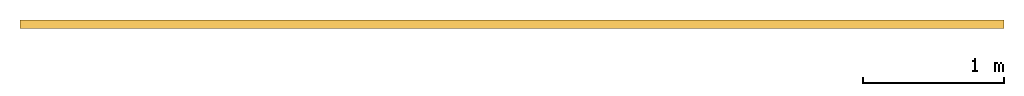
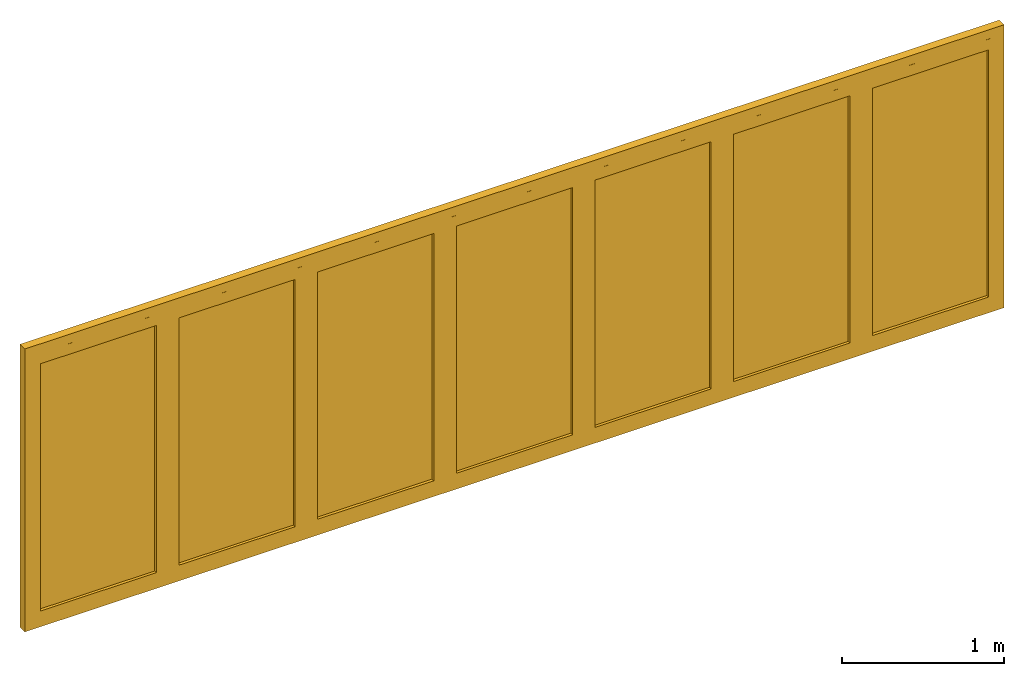
# One storey: 1 door.
"""IFC2X3 building model written with IfcOpenShell, lengths in millimetres."""

from ifc_helpers import new_model, entity, si_unit, converted_unit, direction, frame, frame_2d, origin, origin_2d_with_axis, place, context, subcontext, project, spatial, polyline, rectangle, outline, extrude, source, transform, mapped, material, material_list, type_object, type_shapes, element, save


model = new_model("IFC2X3")

# Units and contexts
model_context = context("Model", 3, precision=1e-06, world=origin(), true_north=direction((2.0, -1.71512652170913e-15, 1.0)))
context_of_model = context(None, 3, precision=1e-06, world=origin(), true_north=direction((2.0, -1.71512652170913e-15, 1.0)))
body_context = subcontext(model_context, "Body", "Model", "MODEL_VIEW")
ifc_project = project(units=[si_unit("LENGTHUNIT", "METRE", prefix="MILLI"), si_unit("AREAUNIT", "SQUARE_METRE", prefix="MILLI"), si_unit("VOLUMEUNIT", "CUBIC_METRE", prefix="MILLI"), converted_unit("PLANEANGLEUNIT", "DEGREE", entity("IfcRatioMeasure", 0.0174532925199433), si_unit("PLANEANGLEUNIT", "RADIAN"), dimensions=[0, 0, 0, 0, 0, 0, 0]), si_unit("TIMEUNIT", "SECOND")], contexts=[model_context, context_of_model])

# Site, building, storey
site_placement = place(None, origin())
site = spatial("IfcSite", under=ifc_project, at=site_placement, CompositionType="ELEMENT")
building_placement = place(site_placement, origin())
building = spatial("IfcBuilding", under=site, at=building_placement, CompositionType="ELEMENT")
storey_placement = place(building_placement, origin())
storey = spatial("IfcBuildingStorey", under=building, at=storey_placement, Name="Ground Floor", CompositionType="ELEMENT", Elevation=0.0)

# Door
ifc_material_1 = material(Name="Glass-Blue")
ifc_material_2 = material(Name="Mtl-Aluminium")
ifc_material_list = material_list([ifc_material_1, ifc_material_2])
door_style = type_object("IfcDoorStyle", ConstructionType="NOTDEFINED", OperationType="NOTDEFINED", ParameterTakesPrecedence=False, Sizeable=False)
shared_shape = source(origin(), body_context, "Body", "SweptSolid", [
    extrude(rectangle(XDim=829.9714, YDim=18.0, at=frame_2d((5.6843418860808e-13, 1.68753899743024e-14), x_axis=(1.0, 0.0))), frame((6924.4291, 270.25, 80.7), z_axis=(0.0, 0.0, 1.0), x_axis=(-1.0, 0.0, 0.0)), (0.0, 0.0, 1.0), 1868.6),
    extrude(outline(polyline([(-495.685699999999, -1015.0), (495.6857, -1015.0), (495.6857, 1015.0), (-495.685699999999, 1015.0), (-495.685699999999, -1015.0)]), holes=[polyline([(414.9857, 934.3), (414.9857, -934.3), (-414.985699999999, -934.3), (-414.985699999999, 934.3), (414.9857, 934.3)])]), frame((6924.4291, 240.5, 1015.0), z_axis=(0.0, 1.0, 0.0), x_axis=(-1.0, 0.0, 0.0)), (0.0, 0.0, 1.0), 59.5),
    extrude(rectangle(XDim=829.9715, YDim=18.0, at=frame_2d((5.40012479177676e-13, 1.68753899743024e-14), x_axis=(1.0, 0.0))), frame((5933.05765, 270.25, 80.7), z_axis=(0.0, 0.0, 1.0), x_axis=(-1.0, 0.0, 0.0)), (0.0, 0.0, 1.0), 1868.6),
    extrude(outline(polyline([(-495.68575, -1015.0), (495.685750000001, -1015.0), (495.685750000001, 1015.0), (-495.68575, 1015.0), (-495.68575, -1015.0)]), holes=[polyline([(414.985750000001, 934.3), (414.985750000001, -934.3), (-414.98575, -934.3), (-414.98575, 934.3), (414.985750000001, 934.3)])]), frame((5933.05765, 240.5, 1015.0), z_axis=(0.0, 1.0, 0.0), x_axis=(-1.0, 0.0, 0.0)), (0.0, 0.0, 1.0), 59.5),
    extrude(rectangle(XDim=829.97139, YDim=18.0, at=frame_2d((0.0, 1.68753899743024e-14), x_axis=(1.0, 0.0))), frame((4941.686205, 270.25, 80.7), z_axis=(0.0, 0.0, 1.0), x_axis=(-1.0, 0.0, 0.0)), (0.0, 0.0, 1.0), 1868.6),
    extrude(outline(polyline([(-495.685695, -1015.0), (495.685695, -1015.0), (495.685695, 1015.0), (-495.685695, 1015.0), (-495.685695, -1015.0)]), holes=[polyline([(414.985694999999, 934.3), (414.985694999999, -934.3), (-414.985695000001, -934.3), (-414.985695000001, 934.3), (414.985694999999, 934.3)])]), frame((4941.686205, 240.5, 1015.0), z_axis=(0.0, 1.0, 0.0), x_axis=(-1.0, 0.0, 0.0)), (0.0, 0.0, 1.0), 59.5),
    extrude(rectangle(XDim=829.97142, YDim=18.0, at=frame_2d((0.0, 1.68753899743024e-14), x_axis=(1.0, 0.0))), frame((3950.3148, 270.25, 80.7), z_axis=(0.0, 0.0, 1.0), x_axis=(-1.0, 0.0, 0.0)), (0.0, 0.0, 1.0), 1868.6),
    extrude(outline(polyline([(-495.685709999999, -1015.0), (495.68571, -1015.0), (495.68571, 1015.0), (-495.685709999999, 1015.0), (-495.685709999999, -1015.0)]), holes=[polyline([(414.985710000001, 934.3), (414.985710000001, -934.3), (-414.985709999999, -934.3), (-414.985709999999, 934.3), (414.985710000001, 934.3)])]), frame((3950.3148, 240.5, 1015.0), z_axis=(0.0, 1.0, 0.0), x_axis=(-1.0, 0.0, 0.0)), (0.0, 0.0, 1.0), 59.5),
    extrude(rectangle(XDim=829.97139, YDim=18.0, at=frame_2d((0.0, 1.68753899743024e-14), x_axis=(1.0, 0.0))), frame((2958.943395, 270.25, 80.7), z_axis=(0.0, 0.0, 1.0), x_axis=(-1.0, 0.0, 0.0)), (0.0, 0.0, 1.0), 1868.6),
    extrude(outline(polyline([(-495.685695, -1015.0), (495.685695000001, -1015.0), (495.685695000001, 1015.0), (-495.685695, 1015.0), (-495.685695, -1015.0)]), holes=[polyline([(414.985695000001, 934.3), (414.985695000001, -934.3), (-414.985694999999, -934.3), (-414.985694999999, 934.3), (414.985695000001, 934.3)])]), frame((2958.943395, 240.5, 1015.0), z_axis=(0.0, 1.0, 0.0), x_axis=(-1.0, 0.0, 0.0)), (0.0, 0.0, 1.0), 59.5),
    extrude(rectangle(XDim=829.9715, YDim=18.0, at=frame_2d((-1.4210854715202e-13, 1.68753899743024e-14), x_axis=(1.0, 0.0))), frame((1967.57195, 270.25, 80.7), z_axis=(0.0, 0.0, 1.0), x_axis=(-1.0, 0.0, 0.0)), (0.0, 0.0, 1.0), 1868.6),
    extrude(outline(polyline([(-495.68575, -1015.0), (495.68575, -1015.0), (495.68575, 1015.0), (-495.68575, 1015.0), (-495.68575, -1015.0)]), holes=[polyline([(414.98575, 934.3), (414.98575, -934.3), (-414.98575, -934.3), (-414.98575, 934.3), (414.98575, 934.3)])]), frame((1967.57195, 240.5, 1015.0), z_axis=(0.0, 1.0, 0.0), x_axis=(-1.0, 0.0, 0.0)), (0.0, 0.0, 1.0), 59.5),
    extrude(rectangle(XDim=829.9714, YDim=18.0, at=frame_2d((-1.4210854715202e-13, 1.68753899743024e-14), x_axis=(1.0, 0.0))), frame((976.2005, 270.25, 80.7), z_axis=(0.0, 0.0, 1.0), x_axis=(-1.0, 0.0, 0.0)), (0.0, 0.0, 1.0), 1868.6),
    extrude(outline(polyline([(-495.6857, -1015.0), (495.6857, -1015.0), (495.6857, 1015.0), (-495.6857, 1015.0), (-495.6857, -1015.0)]), holes=[polyline([(414.9857, 934.3), (414.9857, -934.3), (-414.9857, -934.3), (-414.9857, 934.3), (414.9857, 934.3)])]), frame((976.2005, 240.5, 1015.0), z_axis=(0.0, 1.0, 0.0), x_axis=(-1.0, 0.0, 0.0)), (0.0, 0.0, 1.0), 59.5),
    extrude(rectangle(XDim=30.1999999999998, YDim=59.4, at=frame_2d((-3.37507799486048e-14, 0.0), x_axis=(1.0, 0.0))), frame((465.4148, 270.3, 0.0), z_axis=(0.0, 0.0, 1.0), x_axis=(-1.0, 0.0, 0.0)), (0.0, 0.0, 1.0), 2030.0),
    extrude(rectangle(XDim=30.1999999999996, YDim=59.4, at=origin_2d_with_axis()), frame((7435.2148, 270.3, 0.0), z_axis=(0.0, 0.0, 1.0), x_axis=(-1.0, 0.0, 0.0)), (0.0, 0.0, 1.0), 2030.0),
    extrude(rectangle(XDim=7000.0, YDim=59.4, at=origin_2d_with_axis()), frame((3950.3148, 270.3, 2030.0), z_axis=(0.0, 0.0, 1.0), x_axis=(-1.0, 0.0, 0.0)), (0.0, 0.0, 1.0), 70.0000000000001),
    extrude(rectangle(XDim=7000.0, YDim=59.4, at=origin_2d_with_axis()), frame((3950.3148, 270.3, -38.5), z_axis=(0.0, 0.0, 1.0), x_axis=(-1.0, 0.0, 0.0)), (0.0, 0.0, 1.0), 38.5),
])
type_shapes(door_style, [shared_shape])
door_placement = place(storey_placement, origin())
element("IfcDoor", 1, at=door_placement, inside=storey, type_object=door_style, material=ifc_material_list, OverallHeight=2138.5, OverallWidth=7000.0, context=body_context, shape_type="MappedRepresentation", body=[
    mapped(shared_shape, transform((0.0, 0.0, 0.0), scale=1.0)),
])

save(model, "model.ifc")
